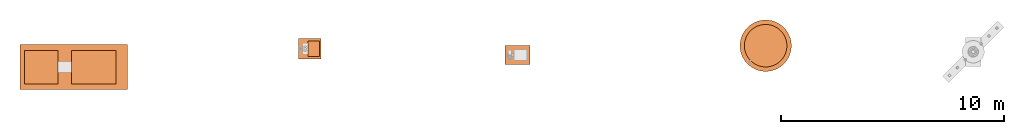
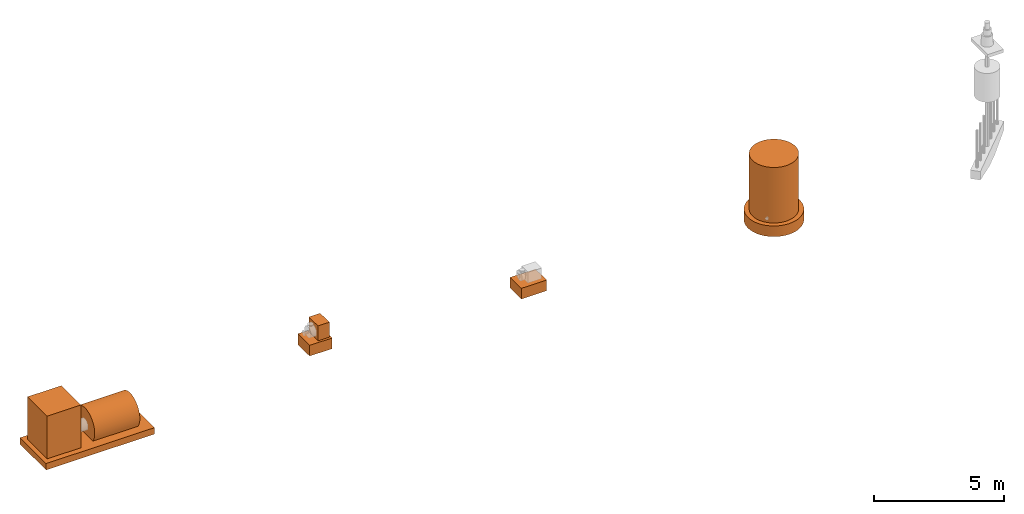
# One storey, part 1 of 5: 8 proxies.
"""IFC2X3 building model written with IfcOpenShell, lengths in millimetres."""

from ifc_helpers import new_model, entity, si_unit, converted_unit, direction, frame, origin_with_axes, origin_2d_with_axis, place, context, project, spatial, rectangle, circle, extrude, source, transform, mapped, element, save


model = new_model("IFC2X3")

# Units and contexts
model_context = context("Model", 3, precision=1e-05, world=origin_with_axes(), true_north=direction((0.0, 1.0)))
ifc_project = project(units=[si_unit("LENGTHUNIT", "METRE", prefix="MILLI"), si_unit("AREAUNIT", "SQUARE_METRE"), si_unit("VOLUMEUNIT", "CUBIC_METRE"), converted_unit("PLANEANGLEUNIT", "DEGREE", entity("IfcPlaneAngleMeasure", 0.017453293), si_unit("PLANEANGLEUNIT", "RADIAN"), dimensions=[0, 0, 0, 0, 0, 0, 0]), si_unit("SOLIDANGLEUNIT", "STERADIAN"), si_unit("MASSUNIT", "GRAM"), si_unit("TIMEUNIT", "SECOND"), si_unit("THERMODYNAMICTEMPERATUREUNIT", "DEGREE_CELSIUS"), si_unit("LUMINOUSINTENSITYUNIT", "LUMEN")], contexts=[model_context])

# Site, building, storey
site_placement = place(None, origin_with_axes())
site = spatial("IfcSite", under=ifc_project, at=site_placement, CompositionType="ELEMENT")
building_placement = place(site_placement, origin_with_axes())
building = spatial("IfcBuilding", under=site, at=building_placement, Name="Default Building", CompositionType="ELEMENT")
storey_placement = place(building_placement, frame((0.0, 0.0, 8000.0), z_axis=(0.0, 0.0, 1.0), x_axis=(1.0, 0.0, 0.0)))
storey = spatial("IfcBuildingStorey", under=building, at=storey_placement, Name="2FL", CompositionType="ELEMENT", Elevation=8000.0)

# Proxies
shared_shape_1 = source(origin_with_axes(), model_context, "Body", "SweptSolid", [
    extrude(rectangle(XDim=500.0, YDim=700.0, at=origin_2d_with_axis()), origin_with_axes(), (0.0, 0.0, 1.0), 700.0),
])
proxy_1_placement = place(storey_placement, frame((23497.348182, 14442.234039, 1509.262437), z_axis=(0.0, 0.0, 1.0), x_axis=(1.0, 0.0, 0.0)))
element("IfcBuildingElementProxy", 1, at=proxy_1_placement, inside=storey, context=model_context, shape_type="MappedRepresentation", body=[
    mapped(shared_shape_1, transform((0.0, 0.0, 0.0))),
])
shared_shape_2 = source(origin_with_axes(), model_context, "Body", "SweptSolid", [
    extrude(circle(Radius=750.0, at=origin_2d_with_axis()), frame((0.0, 0.0, 0.0), z_axis=(-3.69778549322349e-32, 0.0, 1.0), x_axis=(1.0, 0.0, 3.69778549322349e-32)), (0.0, 0.0, 1.0), 2000.0),
])
proxy_2_placement = place(storey_placement, frame((14653.069313, 13622.714996, 1620.56324), z_axis=(-1.0, 0.0, 6.12303176911189e-17), x_axis=(6.12303176911189e-17, 0.0, 1.0)))
element("IfcBuildingElementProxy", 2, at=proxy_2_placement, inside=storey, context=model_context, shape_type="MappedRepresentation", body=[
    mapped(shared_shape_2, transform((0.0, 0.0, 0.0))),
])
shared_shape_3 = source(origin_with_axes(), model_context, "Body", "SweptSolid", [
    extrude(rectangle(XDim=4800.0, YDim=2000.0, at=origin_2d_with_axis()), origin_with_axes(), (0.0, 0.0, 1.0), 300.0),
])
proxy_3_placement = place(storey_placement, frame((12753.069313, 13622.714996, 870.56324), z_axis=(0.0, 0.0, 1.0), x_axis=(1.0, 0.0, 0.0)))
element("IfcBuildingElementProxy", 3, at=proxy_3_placement, inside=storey, context=model_context, shape_type="MappedRepresentation", body=[
    mapped(shared_shape_3, transform((0.0, 0.0, 0.0))),
])
shared_shape_4 = source(origin_with_axes(), model_context, "Body", "SweptSolid", [
    extrude(rectangle(XDim=1500.0, YDim=1500.0, at=origin_2d_with_axis()), origin_with_axes(), (0.0, 0.0, 1.0), 2000.0),
])
proxy_4_placement = place(storey_placement, frame((11294.580424, 13622.714996, 1170.56324), z_axis=(0.0, 0.0, 1.0), x_axis=(1.0, 0.0, 0.0)))
element("IfcBuildingElementProxy", 4, at=proxy_4_placement, inside=storey, context=model_context, shape_type="MappedRepresentation", body=[
    mapped(shared_shape_4, transform((0.0, 0.0, 0.0))),
])
shared_shape_5 = source(origin_with_axes(), model_context, "Body", "SweptSolid", [
    extrude(rectangle(XDim=1000.0, YDim=900.0, at=origin_2d_with_axis()), origin_with_axes(), (0.0, 0.0, 1.0), 500.0),
])
proxy_5_placement = place(storey_placement, frame((23318.348182, 14442.234039, 1009.262437), z_axis=(0.0, 0.0, 1.0), x_axis=(1.0, 0.0, 0.0)))
element("IfcBuildingElementProxy", 5, at=proxy_5_placement, inside=storey, context=model_context, shape_type="MappedRepresentation", body=[
    mapped(shared_shape_5, transform((0.0, 0.0, 0.0))),
])
shared_shape_6 = source(origin_with_axes(), model_context, "Body", "SweptSolid", [
    extrude(rectangle(XDim=1120.0, YDim=850.0, at=origin_2d_with_axis()), origin_with_axes(), (0.0, 0.0, 1.0), 500.0),
])
proxy_6_placement = place(storey_placement, frame((32611.794665, 14169.065113, 598.076211), z_axis=(0.0, 0.0, 1.0), x_axis=(1.0, 0.0, 0.0)))
element("IfcBuildingElementProxy", 6, at=proxy_6_placement, inside=storey, context=model_context, shape_type="MappedRepresentation", body=[
    mapped(shared_shape_6, transform((0.0, 0.0, 0.0))),
])
shared_shape_7 = source(origin_with_axes(), model_context, "Body", "SweptSolid", [
    extrude(circle(Radius=950.0, at=origin_2d_with_axis()), origin_with_axes(), (0.0, 0.0, 1.0), 2600.0),
])
proxy_7_placement = place(storey_placement, frame((43724.827576, 14578.818512, 232.050808), z_axis=(0.0, 0.0, 1.0), x_axis=(1.0, 0.0, 0.0)))
element("IfcBuildingElementProxy", 7, at=proxy_7_placement, inside=storey, context=model_context, shape_type="MappedRepresentation", body=[
    mapped(shared_shape_7, transform((0.0, 0.0, 0.0))),
])
shared_shape_8 = source(origin_with_axes(), model_context, "Body", "SweptSolid", [
    extrude(circle(Radius=1150.0, at=origin_2d_with_axis()), origin_with_axes(), (0.0, 0.0, 1.0), 500.0),
])
proxy_8_placement = place(storey_placement, frame((43724.827576, 14578.818512, -267.949192), z_axis=(0.0, 0.0, 1.0), x_axis=(1.0, 0.0, 0.0)))
element("IfcBuildingElementProxy", 8, at=proxy_8_placement, inside=storey, context=model_context, shape_type="MappedRepresentation", body=[
    mapped(shared_shape_8, transform((0.0, 0.0, 0.0))),
])

save(model, "model.ifc")
